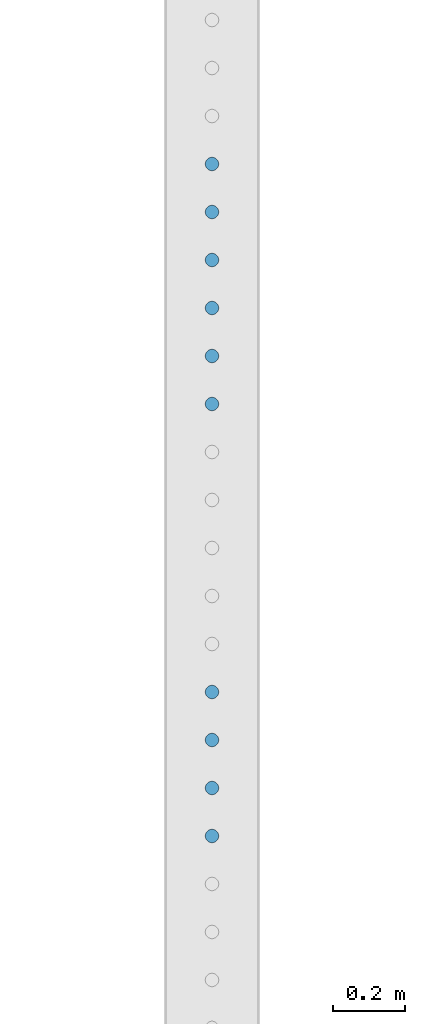
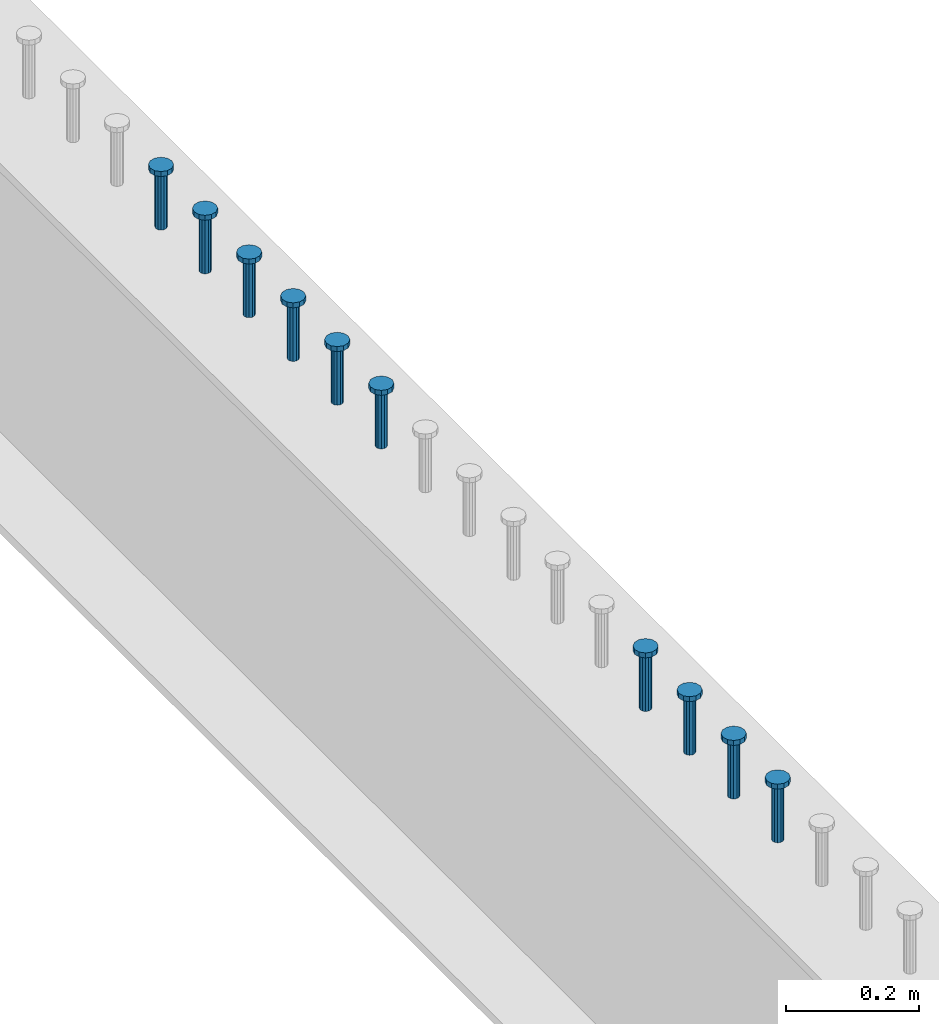
# One storey, part 944 of 1763: 10 columns, 10 elements without a shape of their own.
"""IFC2X3 building model written with IfcOpenShell, lengths in millimetres."""

from ifc_helpers import new_model, si_unit, frame, origin_with_axes, place, context, subcontext, project, spatial, faceted_brep, material, type_object, element, aggregate, save


model = new_model("IFC2X3")

# Units and contexts
model_context = context("Model", 3, precision=1e-05, world=origin_with_axes())
body_context = subcontext(model_context, "Body", "Model", "MODEL_VIEW")
ifc_project = project(units=[si_unit("LENGTHUNIT", "METRE", prefix="MILLI"), si_unit("AREAUNIT", "SQUARE_METRE"), si_unit("VOLUMEUNIT", "CUBIC_METRE"), si_unit("MASSUNIT", "GRAM", prefix="KILO"), si_unit("TIMEUNIT", "SECOND"), si_unit("PLANEANGLEUNIT", "RADIAN"), si_unit("SOLIDANGLEUNIT", "STERADIAN"), si_unit("THERMODYNAMICTEMPERATUREUNIT", "DEGREE_CELSIUS"), si_unit("LUMINOUSINTENSITYUNIT", "LUMEN")], contexts=[model_context])

# Site, building, storey
site_placement = place(None, origin_with_axes())
site = spatial("IfcSite", under=ifc_project, at=site_placement, CompositionType="ELEMENT")
building_placement = place(site_placement, origin_with_axes())
building = spatial("IfcBuilding", under=site, at=building_placement, Name="Undefined", CompositionType="ELEMENT")
storey_placement = place(building_placement, origin_with_axes())
storey = spatial("IfcBuildingStorey", under=building, at=storey_placement, Name="Undefined", CompositionType="ELEMENT", Elevation=0.0)

# Assembly, column
assembly_1_placement = place(storey_placement, origin_with_axes())
assembly_1 = element("IfcElementAssembly", 1, at=assembly_1_placement, inside=storey, Name="STUD", AssemblyPlace="NOTDEFINED", PredefinedType="RIGID_FRAME")
ifc_material = material(Name="STEEL/A108")
column_type = type_object("IfcColumnType", Name="STUD_3/4-DIA", PredefinedType="NOTDEFINED")
column_1_placement = place(assembly_1_placement, frame((-24027.8372736984, 36950.0625, 5194.3), z_axis=(-1.0, 0.0, 0.0), x_axis=(0.0, 0.0, 1.0)))
column_1 = element("IfcColumn", 2, at=column_1_placement, type_object=column_type, material=ifc_material, Name="STUD", ObjectType="STUD_3/4-DIA", context=body_context, shape_type="Brep", body=[
    faceted_brep([(0.0, -9.52000045776367, 0.0), (0.0, -8.25, -4.76000022888184), (104.013, -8.25, -4.76000022888184), (104.013, -9.52000045776367, 0.0), (0.0, -4.76000022888184, -8.25), (104.013, -4.76000022888184, -8.25), (0.0, 0.0, -9.52000045776367), (104.013, 0.0, -9.52000045776367), (0.0, 4.76000022888184, -8.25), (104.013, 4.76000022888184, -8.25), (0.0, 8.25, -4.76000022888184), (104.013, 8.25, -4.76000022888184), (0.0, 9.52000045776367, 0.0), (104.013, 9.52000045776367, 0.0), (0.0, 8.25, 4.76000022888184), (104.013, 8.25, 4.76000022888184), (0.0, 4.76000022888184, 8.25), (104.013, 4.76000022888184, 8.25), (0.0, 0.0, 9.52000045776367), (104.013, 0.0, 9.52000045776367), (0.0, -4.76000022888184, 8.25), (104.013, -4.76000022888184, 8.25), (0.0, -8.25, 4.76000022888184), (104.013, -8.25, 4.76000022888184), (105.156, -16.5, -9.52000045776367), (105.156, -19.0499992370605, 0.0), (105.156, -9.52000045776367, -16.5), (105.156, 0.0, -19.0499992370605), (105.156, 9.52000045776367, -16.5), (105.156, 16.5, -9.52000045776367), (105.156, 19.0499992370605, 0.0), (105.156, 16.5, 9.52000045776367), (105.156, 9.52000045776367, 16.5), (105.156, 0.0, 19.0499992370605), (105.156, -9.52000045776367, 16.5), (105.156, -16.5, 9.52000045776367), (114.3, -16.5, -9.52000045776367), (114.299998441489, -19.0500000000029, 0.0), (114.3, -9.52000045776367, -16.5), (114.3, 0.0, -19.0499992370605), (114.3, 9.52000045776367, -16.5), (114.3, 16.5, -9.52000045776367), (114.299998441489, 19.0500000000029, 0.0), (114.3, 16.5, 9.52000045776367), (114.3, 9.52000045776367, 16.5), (114.3, 0.0, 19.0499992370605), (114.3, -9.52000045776367, 16.5), (114.3, -16.5, 9.52000045776367)], [[[0, 1, 2, 3]], [[1, 4, 5, 2]], [[4, 6, 7, 5]], [[6, 8, 9, 7]], [[8, 10, 11, 9]], [[10, 12, 13, 11]], [[12, 14, 15, 13]], [[14, 16, 17, 15]], [[16, 18, 19, 17]], [[18, 20, 21, 19]], [[20, 22, 23, 21]], [[22, 0, 3, 23]], [[22, 20, 18, 16, 14, 12, 10, 8, 6, 4, 1, 0]], [[3, 2, 24, 25]], [[2, 5, 26, 24]], [[5, 7, 27, 26]], [[7, 9, 28, 27]], [[9, 11, 29, 28]], [[11, 13, 30, 29]], [[13, 15, 31, 30]], [[15, 17, 32, 31]], [[17, 19, 33, 32]], [[19, 21, 34, 33]], [[21, 23, 35, 34]], [[23, 3, 25, 35]], [[25, 24, 36, 37]], [[24, 26, 38, 36]], [[26, 27, 39, 38]], [[27, 28, 40, 39]], [[28, 29, 41, 40]], [[29, 30, 42, 41]], [[30, 31, 43, 42]], [[31, 32, 44, 43]], [[32, 33, 45, 44]], [[33, 34, 46, 45]], [[34, 35, 47, 46]], [[35, 25, 37, 47]], [[38, 39, 40, 41, 42, 43, 44, 45, 46, 47, 37, 36]]]),
])
aggregate(assembly_1, [column_1])

assembly_2_placement = place(storey_placement, origin_with_axes())
assembly_2 = element("IfcElementAssembly", 3, at=assembly_2_placement, inside=storey, Name="STUD", AssemblyPlace="NOTDEFINED", PredefinedType="RIGID_FRAME")
column_2_placement = place(assembly_2_placement, frame((-24027.8372736984, 36817.4545, 5194.3), z_axis=(-1.0, 0.0, 0.0), x_axis=(0.0, 0.0, 1.0)))
column_2 = element("IfcColumn", 4, at=column_2_placement, type_object=column_type, material=ifc_material, Name="STUD", ObjectType="STUD_3/4-DIA", context=body_context, shape_type="Brep", body=[
    faceted_brep([(0.0, -9.52000045776367, 0.0), (0.0, -8.25, -4.76000022888184), (104.013, -8.25, -4.76000022888184), (104.013, -9.52000045776367, 0.0), (0.0, -4.76000022888184, -8.25), (104.013, -4.76000022888184, -8.25), (0.0, 0.0, -9.52000045776367), (104.013, 0.0, -9.52000045776367), (0.0, 4.76000022888184, -8.25), (104.013, 4.76000022888184, -8.25), (0.0, 8.25, -4.76000022888184), (104.013, 8.25, -4.76000022888184), (0.0, 9.52000045776367, 0.0), (104.013, 9.52000045776367, 0.0), (0.0, 8.25, 4.76000022888184), (104.013, 8.25, 4.76000022888184), (0.0, 4.76000022888184, 8.25), (104.013, 4.76000022888184, 8.25), (0.0, 0.0, 9.52000045776367), (104.013, 0.0, 9.52000045776367), (0.0, -4.76000022888184, 8.25), (104.013, -4.76000022888184, 8.25), (0.0, -8.25, 4.76000022888184), (104.013, -8.25, 4.76000022888184), (105.156, -16.5, -9.52000045776367), (105.156, -19.0499992370605, 0.0), (105.156, -9.52000045776367, -16.5), (105.156, 0.0, -19.0499992370605), (105.156, 9.52000045776367, -16.5), (105.156, 16.5, -9.52000045776367), (105.156, 19.0499992370605, 0.0), (105.156, 16.5, 9.52000045776367), (105.156, 9.52000045776367, 16.5), (105.156, 0.0, 19.0499992370605), (105.156, -9.52000045776367, 16.5), (105.156, -16.5, 9.52000045776367), (114.3, -16.5, -9.52000045776367), (114.299998441489, -19.0500000000029, 0.0), (114.3, -9.52000045776367, -16.5), (114.3, 0.0, -19.0499992370605), (114.3, 9.52000045776367, -16.5), (114.3, 16.5, -9.52000045776367), (114.299998441489, 19.0500000000029, 0.0), (114.3, 16.5, 9.52000045776367), (114.3, 9.52000045776367, 16.5), (114.3, 0.0, 19.0499992370605), (114.3, -9.52000045776367, 16.5), (114.3, -16.5, 9.52000045776367)], [[[0, 1, 2, 3]], [[1, 4, 5, 2]], [[4, 6, 7, 5]], [[6, 8, 9, 7]], [[8, 10, 11, 9]], [[10, 12, 13, 11]], [[12, 14, 15, 13]], [[14, 16, 17, 15]], [[16, 18, 19, 17]], [[18, 20, 21, 19]], [[20, 22, 23, 21]], [[22, 0, 3, 23]], [[22, 20, 18, 16, 14, 12, 10, 8, 6, 4, 1, 0]], [[3, 2, 24, 25]], [[2, 5, 26, 24]], [[5, 7, 27, 26]], [[7, 9, 28, 27]], [[9, 11, 29, 28]], [[11, 13, 30, 29]], [[13, 15, 31, 30]], [[15, 17, 32, 31]], [[17, 19, 33, 32]], [[19, 21, 34, 33]], [[21, 23, 35, 34]], [[23, 3, 25, 35]], [[25, 24, 36, 37]], [[24, 26, 38, 36]], [[26, 27, 39, 38]], [[27, 28, 40, 39]], [[28, 29, 41, 40]], [[29, 30, 42, 41]], [[30, 31, 43, 42]], [[31, 32, 44, 43]], [[32, 33, 45, 44]], [[33, 34, 46, 45]], [[34, 35, 47, 46]], [[35, 25, 37, 47]], [[38, 39, 40, 41, 42, 43, 44, 45, 46, 47, 37, 36]]]),
])
aggregate(assembly_2, [column_2])

assembly_3_placement = place(storey_placement, origin_with_axes())
assembly_3 = element("IfcElementAssembly", 5, at=assembly_3_placement, inside=storey, Name="STUD", AssemblyPlace="NOTDEFINED", PredefinedType="RIGID_FRAME")
column_3_placement = place(assembly_3_placement, frame((-24027.8372736984, 36684.8465, 5194.3), z_axis=(-1.0, 0.0, 0.0), x_axis=(0.0, 0.0, 1.0)))
column_3 = element("IfcColumn", 6, at=column_3_placement, type_object=column_type, material=ifc_material, Name="STUD", ObjectType="STUD_3/4-DIA", context=body_context, shape_type="Brep", body=[
    faceted_brep([(0.0, -9.52000045776367, 0.0), (0.0, -8.25, -4.76000022888184), (104.013, -8.25, -4.76000022888184), (104.013, -9.52000045776367, 0.0), (0.0, -4.76000022888184, -8.25), (104.013, -4.76000022888184, -8.25), (0.0, 0.0, -9.52000045776367), (104.013, 0.0, -9.52000045776367), (0.0, 4.76000022888184, -8.25), (104.013, 4.76000022888184, -8.25), (0.0, 8.25, -4.76000022888184), (104.013, 8.25, -4.76000022888184), (0.0, 9.52000045776367, 0.0), (104.013, 9.52000045776367, 0.0), (0.0, 8.25, 4.76000022888184), (104.013, 8.25, 4.76000022888184), (0.0, 4.76000022888184, 8.25), (104.013, 4.76000022888184, 8.25), (0.0, 0.0, 9.52000045776367), (104.013, 0.0, 9.52000045776367), (0.0, -4.76000022888184, 8.25), (104.013, -4.76000022888184, 8.25), (0.0, -8.25, 4.76000022888184), (104.013, -8.25, 4.76000022888184), (105.156, -16.5, -9.52000045776367), (105.156, -19.0499992370605, 0.0), (105.156, -9.52000045776367, -16.5), (105.156, 0.0, -19.0499992370605), (105.156, 9.52000045776367, -16.5), (105.156, 16.5, -9.52000045776367), (105.156, 19.0499992370605, 0.0), (105.156, 16.5, 9.52000045776367), (105.156, 9.52000045776367, 16.5), (105.156, 0.0, 19.0499992370605), (105.156, -9.52000045776367, 16.5), (105.156, -16.5, 9.52000045776367), (114.3, -16.5, -9.52000045776367), (114.299998441489, -19.0500000000029, 0.0), (114.3, -9.52000045776367, -16.5), (114.3, 0.0, -19.0499992370605), (114.3, 9.52000045776367, -16.5), (114.3, 16.5, -9.52000045776367), (114.299998441489, 19.0500000000029, 0.0), (114.3, 16.5, 9.52000045776367), (114.3, 9.52000045776367, 16.5), (114.3, 0.0, 19.0499992370605), (114.3, -9.52000045776367, 16.5), (114.3, -16.5, 9.52000045776367)], [[[0, 1, 2, 3]], [[1, 4, 5, 2]], [[4, 6, 7, 5]], [[6, 8, 9, 7]], [[8, 10, 11, 9]], [[10, 12, 13, 11]], [[12, 14, 15, 13]], [[14, 16, 17, 15]], [[16, 18, 19, 17]], [[18, 20, 21, 19]], [[20, 22, 23, 21]], [[22, 0, 3, 23]], [[22, 20, 18, 16, 14, 12, 10, 8, 6, 4, 1, 0]], [[3, 2, 24, 25]], [[2, 5, 26, 24]], [[5, 7, 27, 26]], [[7, 9, 28, 27]], [[9, 11, 29, 28]], [[11, 13, 30, 29]], [[13, 15, 31, 30]], [[15, 17, 32, 31]], [[17, 19, 33, 32]], [[19, 21, 34, 33]], [[21, 23, 35, 34]], [[23, 3, 25, 35]], [[25, 24, 36, 37]], [[24, 26, 38, 36]], [[26, 27, 39, 38]], [[27, 28, 40, 39]], [[28, 29, 41, 40]], [[29, 30, 42, 41]], [[30, 31, 43, 42]], [[31, 32, 44, 43]], [[32, 33, 45, 44]], [[33, 34, 46, 45]], [[34, 35, 47, 46]], [[35, 25, 37, 47]], [[38, 39, 40, 41, 42, 43, 44, 45, 46, 47, 37, 36]]]),
])
aggregate(assembly_3, [column_3])

assembly_4_placement = place(storey_placement, origin_with_axes())
assembly_4 = element("IfcElementAssembly", 7, at=assembly_4_placement, inside=storey, Name="STUD", AssemblyPlace="NOTDEFINED", PredefinedType="RIGID_FRAME")
column_4_placement = place(assembly_4_placement, frame((-24027.8372736984, 36552.2385, 5194.3), z_axis=(-1.0, 0.0, 0.0), x_axis=(0.0, 0.0, 1.0)))
column_4 = element("IfcColumn", 8, at=column_4_placement, type_object=column_type, material=ifc_material, Name="STUD", ObjectType="STUD_3/4-DIA", context=body_context, shape_type="Brep", body=[
    faceted_brep([(0.0, -9.52000045776367, 0.0), (0.0, -8.25, -4.76000022888184), (104.013, -8.25, -4.76000022888184), (104.013, -9.52000045776367, 0.0), (0.0, -4.76000022888184, -8.25), (104.013, -4.76000022888184, -8.25), (0.0, 0.0, -9.52000045776367), (104.013, 0.0, -9.52000045776367), (0.0, 4.76000022888184, -8.25), (104.013, 4.76000022888184, -8.25), (0.0, 8.25, -4.76000022888184), (104.013, 8.25, -4.76000022888184), (0.0, 9.52000045776367, 0.0), (104.013, 9.52000045776367, 0.0), (0.0, 8.25, 4.76000022888184), (104.013, 8.25, 4.76000022888184), (0.0, 4.76000022888184, 8.25), (104.013, 4.76000022888184, 8.25), (0.0, 0.0, 9.52000045776367), (104.013, 0.0, 9.52000045776367), (0.0, -4.76000022888184, 8.25), (104.013, -4.76000022888184, 8.25), (0.0, -8.25, 4.76000022888184), (104.013, -8.25, 4.76000022888184), (105.156, -16.5, -9.52000045776367), (105.156, -19.0499992370605, 0.0), (105.156, -9.52000045776367, -16.5), (105.156, 0.0, -19.0499992370605), (105.156, 9.52000045776367, -16.5), (105.156, 16.5, -9.52000045776367), (105.156, 19.0499992370605, 0.0), (105.156, 16.5, 9.52000045776367), (105.156, 9.52000045776367, 16.5), (105.156, 0.0, 19.0499992370605), (105.156, -9.52000045776367, 16.5), (105.156, -16.5, 9.52000045776367), (114.3, -16.5, -9.52000045776367), (114.299998441489, -19.0500000000029, 0.0), (114.3, -9.52000045776367, -16.5), (114.3, 0.0, -19.0499992370605), (114.3, 9.52000045776367, -16.5), (114.3, 16.5, -9.52000045776367), (114.299998441489, 19.0500000000029, 0.0), (114.3, 16.5, 9.52000045776367), (114.3, 9.52000045776367, 16.5), (114.3, 0.0, 19.0499992370605), (114.3, -9.52000045776367, 16.5), (114.3, -16.5, 9.52000045776367)], [[[0, 1, 2, 3]], [[1, 4, 5, 2]], [[4, 6, 7, 5]], [[6, 8, 9, 7]], [[8, 10, 11, 9]], [[10, 12, 13, 11]], [[12, 14, 15, 13]], [[14, 16, 17, 15]], [[16, 18, 19, 17]], [[18, 20, 21, 19]], [[20, 22, 23, 21]], [[22, 0, 3, 23]], [[22, 20, 18, 16, 14, 12, 10, 8, 6, 4, 1, 0]], [[3, 2, 24, 25]], [[2, 5, 26, 24]], [[5, 7, 27, 26]], [[7, 9, 28, 27]], [[9, 11, 29, 28]], [[11, 13, 30, 29]], [[13, 15, 31, 30]], [[15, 17, 32, 31]], [[17, 19, 33, 32]], [[19, 21, 34, 33]], [[21, 23, 35, 34]], [[23, 3, 25, 35]], [[25, 24, 36, 37]], [[24, 26, 38, 36]], [[26, 27, 39, 38]], [[27, 28, 40, 39]], [[28, 29, 41, 40]], [[29, 30, 42, 41]], [[30, 31, 43, 42]], [[31, 32, 44, 43]], [[32, 33, 45, 44]], [[33, 34, 46, 45]], [[34, 35, 47, 46]], [[35, 25, 37, 47]], [[38, 39, 40, 41, 42, 43, 44, 45, 46, 47, 37, 36]]]),
])
aggregate(assembly_4, [column_4])

assembly_5_placement = place(storey_placement, origin_with_axes())
assembly_5 = element("IfcElementAssembly", 9, at=assembly_5_placement, inside=storey, Name="STUD", AssemblyPlace="NOTDEFINED", PredefinedType="RIGID_FRAME")
column_5_placement = place(assembly_5_placement, frame((-24027.8372736984, 36419.6305, 5194.3), z_axis=(-1.0, 0.0, 0.0), x_axis=(0.0, 0.0, 1.0)))
column_5 = element("IfcColumn", 10, at=column_5_placement, type_object=column_type, material=ifc_material, Name="STUD", ObjectType="STUD_3/4-DIA", context=body_context, shape_type="Brep", body=[
    faceted_brep([(0.0, -9.52000045776367, 0.0), (0.0, -8.25, -4.76000022888184), (104.013, -8.25, -4.76000022888184), (104.013, -9.52000045776367, 0.0), (0.0, -4.76000022888184, -8.25), (104.013, -4.76000022888184, -8.25), (0.0, 0.0, -9.52000045776367), (104.013, 0.0, -9.52000045776367), (0.0, 4.76000022888184, -8.25), (104.013, 4.76000022888184, -8.25), (0.0, 8.25, -4.76000022888184), (104.013, 8.25, -4.76000022888184), (0.0, 9.52000045776367, 0.0), (104.013, 9.52000045776367, 0.0), (0.0, 8.25, 4.76000022888184), (104.013, 8.25, 4.76000022888184), (0.0, 4.76000022888184, 8.25), (104.013, 4.76000022888184, 8.25), (0.0, 0.0, 9.52000045776367), (104.013, 0.0, 9.52000045776367), (0.0, -4.76000022888184, 8.25), (104.013, -4.76000022888184, 8.25), (0.0, -8.25, 4.76000022888184), (104.013, -8.25, 4.76000022888184), (105.156, -16.5, -9.52000045776367), (105.156, -19.0499992370605, 0.0), (105.156, -9.52000045776367, -16.5), (105.156, 0.0, -19.0499992370605), (105.156, 9.52000045776367, -16.5), (105.156, 16.5, -9.52000045776367), (105.156, 19.0499992370605, 0.0), (105.156, 16.5, 9.52000045776367), (105.156, 9.52000045776367, 16.5), (105.156, 0.0, 19.0499992370605), (105.156, -9.52000045776367, 16.5), (105.156, -16.5, 9.52000045776367), (114.3, -16.5, -9.52000045776367), (114.299998441489, -19.0500000000029, 0.0), (114.3, -9.52000045776367, -16.5), (114.3, 0.0, -19.0499992370605), (114.3, 9.52000045776367, -16.5), (114.3, 16.5, -9.52000045776367), (114.299998441489, 19.0500000000029, 0.0), (114.3, 16.5, 9.52000045776367), (114.3, 9.52000045776367, 16.5), (114.3, 0.0, 19.0499992370605), (114.3, -9.52000045776367, 16.5), (114.3, -16.5, 9.52000045776367)], [[[0, 1, 2, 3]], [[1, 4, 5, 2]], [[4, 6, 7, 5]], [[6, 8, 9, 7]], [[8, 10, 11, 9]], [[10, 12, 13, 11]], [[12, 14, 15, 13]], [[14, 16, 17, 15]], [[16, 18, 19, 17]], [[18, 20, 21, 19]], [[20, 22, 23, 21]], [[22, 0, 3, 23]], [[22, 20, 18, 16, 14, 12, 10, 8, 6, 4, 1, 0]], [[3, 2, 24, 25]], [[2, 5, 26, 24]], [[5, 7, 27, 26]], [[7, 9, 28, 27]], [[9, 11, 29, 28]], [[11, 13, 30, 29]], [[13, 15, 31, 30]], [[15, 17, 32, 31]], [[17, 19, 33, 32]], [[19, 21, 34, 33]], [[21, 23, 35, 34]], [[23, 3, 25, 35]], [[25, 24, 36, 37]], [[24, 26, 38, 36]], [[26, 27, 39, 38]], [[27, 28, 40, 39]], [[28, 29, 41, 40]], [[29, 30, 42, 41]], [[30, 31, 43, 42]], [[31, 32, 44, 43]], [[32, 33, 45, 44]], [[33, 34, 46, 45]], [[34, 35, 47, 46]], [[35, 25, 37, 47]], [[38, 39, 40, 41, 42, 43, 44, 45, 46, 47, 37, 36]]]),
])
aggregate(assembly_5, [column_5])

assembly_6_placement = place(storey_placement, origin_with_axes())
assembly_6 = element("IfcElementAssembly", 11, at=assembly_6_placement, inside=storey, Name="STUD", AssemblyPlace="NOTDEFINED", PredefinedType="RIGID_FRAME")
column_6_placement = place(assembly_6_placement, frame((-24027.8372736984, 36287.0225, 5194.3), z_axis=(-1.0, 0.0, 0.0), x_axis=(0.0, 0.0, 1.0)))
column_6 = element("IfcColumn", 12, at=column_6_placement, type_object=column_type, material=ifc_material, Name="STUD", ObjectType="STUD_3/4-DIA", context=body_context, shape_type="Brep", body=[
    faceted_brep([(0.0, -9.52000045776367, 0.0), (0.0, -8.25, -4.76000022888184), (104.013, -8.25, -4.76000022888184), (104.013, -9.52000045776367, 0.0), (0.0, -4.76000022888184, -8.25), (104.013, -4.76000022888184, -8.25), (0.0, 0.0, -9.52000045776367), (104.013, 0.0, -9.52000045776367), (0.0, 4.76000022888184, -8.25), (104.013, 4.76000022888184, -8.25), (0.0, 8.25, -4.76000022888184), (104.013, 8.25, -4.76000022888184), (0.0, 9.52000045776367, 0.0), (104.013, 9.52000045776367, 0.0), (0.0, 8.25, 4.76000022888184), (104.013, 8.25, 4.76000022888184), (0.0, 4.76000022888184, 8.25), (104.013, 4.76000022888184, 8.25), (0.0, 0.0, 9.52000045776367), (104.013, 0.0, 9.52000045776367), (0.0, -4.76000022888184, 8.25), (104.013, -4.76000022888184, 8.25), (0.0, -8.25, 4.76000022888184), (104.013, -8.25, 4.76000022888184), (105.156, -16.5, -9.52000045776367), (105.156, -19.0499992370605, 0.0), (105.156, -9.52000045776367, -16.5), (105.156, 0.0, -19.0499992370605), (105.156, 9.52000045776367, -16.5), (105.156, 16.5, -9.52000045776367), (105.156, 19.0499992370605, 0.0), (105.156, 16.5, 9.52000045776367), (105.156, 9.52000045776367, 16.5), (105.156, 0.0, 19.0499992370605), (105.156, -9.52000045776367, 16.5), (105.156, -16.5, 9.52000045776367), (114.3, -16.5, -9.52000045776367), (114.299998441489, -19.0500000000029, 0.0), (114.3, -9.52000045776367, -16.5), (114.3, 0.0, -19.0499992370605), (114.3, 9.52000045776367, -16.5), (114.3, 16.5, -9.52000045776367), (114.299998441489, 19.0500000000029, 0.0), (114.3, 16.5, 9.52000045776367), (114.3, 9.52000045776367, 16.5), (114.3, 0.0, 19.0499992370605), (114.3, -9.52000045776367, 16.5), (114.3, -16.5, 9.52000045776367)], [[[0, 1, 2, 3]], [[1, 4, 5, 2]], [[4, 6, 7, 5]], [[6, 8, 9, 7]], [[8, 10, 11, 9]], [[10, 12, 13, 11]], [[12, 14, 15, 13]], [[14, 16, 17, 15]], [[16, 18, 19, 17]], [[18, 20, 21, 19]], [[20, 22, 23, 21]], [[22, 0, 3, 23]], [[22, 20, 18, 16, 14, 12, 10, 8, 6, 4, 1, 0]], [[3, 2, 24, 25]], [[2, 5, 26, 24]], [[5, 7, 27, 26]], [[7, 9, 28, 27]], [[9, 11, 29, 28]], [[11, 13, 30, 29]], [[13, 15, 31, 30]], [[15, 17, 32, 31]], [[17, 19, 33, 32]], [[19, 21, 34, 33]], [[21, 23, 35, 34]], [[23, 3, 25, 35]], [[25, 24, 36, 37]], [[24, 26, 38, 36]], [[26, 27, 39, 38]], [[27, 28, 40, 39]], [[28, 29, 41, 40]], [[29, 30, 42, 41]], [[30, 31, 43, 42]], [[31, 32, 44, 43]], [[32, 33, 45, 44]], [[33, 34, 46, 45]], [[34, 35, 47, 46]], [[35, 25, 37, 47]], [[38, 39, 40, 41, 42, 43, 44, 45, 46, 47, 37, 36]]]),
])
aggregate(assembly_6, [column_6])

assembly_7_placement = place(storey_placement, origin_with_axes())
assembly_7 = element("IfcElementAssembly", 13, at=assembly_7_placement, inside=storey, Name="STUD", AssemblyPlace="NOTDEFINED", PredefinedType="RIGID_FRAME")
column_7_placement = place(assembly_7_placement, frame((-24027.8372736984, 35491.3745, 5194.3), z_axis=(-1.0, 0.0, 0.0), x_axis=(0.0, 0.0, 1.0)))
column_7 = element("IfcColumn", 14, at=column_7_placement, type_object=column_type, material=ifc_material, Name="STUD", ObjectType="STUD_3/4-DIA", context=body_context, shape_type="Brep", body=[
    faceted_brep([(0.0, -9.52000045776367, 0.0), (0.0, -8.25, -4.76000022888184), (104.013, -8.25, -4.76000022888184), (104.013, -9.52000045776367, 0.0), (0.0, -4.76000022888184, -8.25), (104.013, -4.76000022888184, -8.25), (0.0, 0.0, -9.52000045776367), (104.013, 0.0, -9.52000045776367), (0.0, 4.76000022888184, -8.25), (104.013, 4.76000022888184, -8.25), (0.0, 8.25, -4.76000022888184), (104.013, 8.25, -4.76000022888184), (0.0, 9.52000045776367, 0.0), (104.013, 9.52000045776367, 0.0), (0.0, 8.25, 4.76000022888184), (104.013, 8.25, 4.76000022888184), (0.0, 4.76000022888184, 8.25), (104.013, 4.76000022888184, 8.25), (0.0, 0.0, 9.52000045776367), (104.013, 0.0, 9.52000045776367), (0.0, -4.76000022888184, 8.25), (104.013, -4.76000022888184, 8.25), (0.0, -8.25, 4.76000022888184), (104.013, -8.25, 4.76000022888184), (105.156, -16.5, -9.52000045776367), (105.156, -19.0499992370605, 0.0), (105.156, -9.52000045776367, -16.5), (105.156, 0.0, -19.0499992370605), (105.156, 9.52000045776367, -16.5), (105.156, 16.5, -9.52000045776367), (105.156, 19.0499992370605, 0.0), (105.156, 16.5, 9.52000045776367), (105.156, 9.52000045776367, 16.5), (105.156, 0.0, 19.0499992370605), (105.156, -9.52000045776367, 16.5), (105.156, -16.5, 9.52000045776367), (114.3, -16.5, -9.52000045776367), (114.299998441489, -19.0500000000029, 0.0), (114.3, -9.52000045776367, -16.5), (114.3, 0.0, -19.0499992370605), (114.3, 9.52000045776367, -16.5), (114.3, 16.5, -9.52000045776367), (114.299998441489, 19.0500000000029, 0.0), (114.3, 16.5, 9.52000045776367), (114.3, 9.52000045776367, 16.5), (114.3, 0.0, 19.0499992370605), (114.3, -9.52000045776367, 16.5), (114.3, -16.5, 9.52000045776367)], [[[0, 1, 2, 3]], [[1, 4, 5, 2]], [[4, 6, 7, 5]], [[6, 8, 9, 7]], [[8, 10, 11, 9]], [[10, 12, 13, 11]], [[12, 14, 15, 13]], [[14, 16, 17, 15]], [[16, 18, 19, 17]], [[18, 20, 21, 19]], [[20, 22, 23, 21]], [[22, 0, 3, 23]], [[22, 20, 18, 16, 14, 12, 10, 8, 6, 4, 1, 0]], [[3, 2, 24, 25]], [[2, 5, 26, 24]], [[5, 7, 27, 26]], [[7, 9, 28, 27]], [[9, 11, 29, 28]], [[11, 13, 30, 29]], [[13, 15, 31, 30]], [[15, 17, 32, 31]], [[17, 19, 33, 32]], [[19, 21, 34, 33]], [[21, 23, 35, 34]], [[23, 3, 25, 35]], [[25, 24, 36, 37]], [[24, 26, 38, 36]], [[26, 27, 39, 38]], [[27, 28, 40, 39]], [[28, 29, 41, 40]], [[29, 30, 42, 41]], [[30, 31, 43, 42]], [[31, 32, 44, 43]], [[32, 33, 45, 44]], [[33, 34, 46, 45]], [[34, 35, 47, 46]], [[35, 25, 37, 47]], [[38, 39, 40, 41, 42, 43, 44, 45, 46, 47, 37, 36]]]),
])
aggregate(assembly_7, [column_7])

assembly_8_placement = place(storey_placement, origin_with_axes())
assembly_8 = element("IfcElementAssembly", 15, at=assembly_8_placement, inside=storey, Name="STUD", AssemblyPlace="NOTDEFINED", PredefinedType="RIGID_FRAME")
column_8_placement = place(assembly_8_placement, frame((-24027.8372736984, 35358.7665, 5194.3), z_axis=(-1.0, 0.0, 0.0), x_axis=(0.0, 0.0, 1.0)))
column_8 = element("IfcColumn", 16, at=column_8_placement, type_object=column_type, material=ifc_material, Name="STUD", ObjectType="STUD_3/4-DIA", context=body_context, shape_type="Brep", body=[
    faceted_brep([(0.0, -9.52000045776367, 0.0), (0.0, -8.25, -4.76000022888184), (104.013, -8.25, -4.76000022888184), (104.013, -9.52000045776367, 0.0), (0.0, -4.76000022888184, -8.25), (104.013, -4.76000022888184, -8.25), (0.0, 0.0, -9.52000045776367), (104.013, 0.0, -9.52000045776367), (0.0, 4.76000022888184, -8.25), (104.013, 4.76000022888184, -8.25), (0.0, 8.25, -4.76000022888184), (104.013, 8.25, -4.76000022888184), (0.0, 9.52000045776367, 0.0), (104.013, 9.52000045776367, 0.0), (0.0, 8.25, 4.76000022888184), (104.013, 8.25, 4.76000022888184), (0.0, 4.76000022888184, 8.25), (104.013, 4.76000022888184, 8.25), (0.0, 0.0, 9.52000045776367), (104.013, 0.0, 9.52000045776367), (0.0, -4.76000022888184, 8.25), (104.013, -4.76000022888184, 8.25), (0.0, -8.25, 4.76000022888184), (104.013, -8.25, 4.76000022888184), (105.156, -16.5, -9.52000045776367), (105.156, -19.0499992370605, 0.0), (105.156, -9.52000045776367, -16.5), (105.156, 0.0, -19.0499992370605), (105.156, 9.52000045776367, -16.5), (105.156, 16.5, -9.52000045776367), (105.156, 19.0499992370605, 0.0), (105.156, 16.5, 9.52000045776367), (105.156, 9.52000045776367, 16.5), (105.156, 0.0, 19.0499992370605), (105.156, -9.52000045776367, 16.5), (105.156, -16.5, 9.52000045776367), (114.3, -16.5, -9.52000045776367), (114.299998441489, -19.0500000000029, 0.0), (114.3, -9.52000045776367, -16.5), (114.3, 0.0, -19.0499992370605), (114.3, 9.52000045776367, -16.5), (114.3, 16.5, -9.52000045776367), (114.299998441489, 19.0500000000029, 0.0), (114.3, 16.5, 9.52000045776367), (114.3, 9.52000045776367, 16.5), (114.3, 0.0, 19.0499992370605), (114.3, -9.52000045776367, 16.5), (114.3, -16.5, 9.52000045776367)], [[[0, 1, 2, 3]], [[1, 4, 5, 2]], [[4, 6, 7, 5]], [[6, 8, 9, 7]], [[8, 10, 11, 9]], [[10, 12, 13, 11]], [[12, 14, 15, 13]], [[14, 16, 17, 15]], [[16, 18, 19, 17]], [[18, 20, 21, 19]], [[20, 22, 23, 21]], [[22, 0, 3, 23]], [[22, 20, 18, 16, 14, 12, 10, 8, 6, 4, 1, 0]], [[3, 2, 24, 25]], [[2, 5, 26, 24]], [[5, 7, 27, 26]], [[7, 9, 28, 27]], [[9, 11, 29, 28]], [[11, 13, 30, 29]], [[13, 15, 31, 30]], [[15, 17, 32, 31]], [[17, 19, 33, 32]], [[19, 21, 34, 33]], [[21, 23, 35, 34]], [[23, 3, 25, 35]], [[25, 24, 36, 37]], [[24, 26, 38, 36]], [[26, 27, 39, 38]], [[27, 28, 40, 39]], [[28, 29, 41, 40]], [[29, 30, 42, 41]], [[30, 31, 43, 42]], [[31, 32, 44, 43]], [[32, 33, 45, 44]], [[33, 34, 46, 45]], [[34, 35, 47, 46]], [[35, 25, 37, 47]], [[38, 39, 40, 41, 42, 43, 44, 45, 46, 47, 37, 36]]]),
])
aggregate(assembly_8, [column_8])

assembly_9_placement = place(storey_placement, origin_with_axes())
assembly_9 = element("IfcElementAssembly", 17, at=assembly_9_placement, inside=storey, Name="STUD", AssemblyPlace="NOTDEFINED", PredefinedType="RIGID_FRAME")
column_9_placement = place(assembly_9_placement, frame((-24027.8372736984, 35226.1585, 5194.3), z_axis=(-1.0, 0.0, 0.0), x_axis=(0.0, 0.0, 1.0)))
column_9 = element("IfcColumn", 18, at=column_9_placement, type_object=column_type, material=ifc_material, Name="STUD", ObjectType="STUD_3/4-DIA", context=body_context, shape_type="Brep", body=[
    faceted_brep([(0.0, -9.52000045776367, 0.0), (0.0, -8.25, -4.76000022888184), (104.013, -8.25, -4.76000022888184), (104.013, -9.52000045776367, 0.0), (0.0, -4.76000022888184, -8.25), (104.013, -4.76000022888184, -8.25), (0.0, 0.0, -9.52000045776367), (104.013, 0.0, -9.52000045776367), (0.0, 4.76000022888184, -8.25), (104.013, 4.76000022888184, -8.25), (0.0, 8.25, -4.76000022888184), (104.013, 8.25, -4.76000022888184), (0.0, 9.52000045776367, 0.0), (104.013, 9.52000045776367, 0.0), (0.0, 8.25, 4.76000022888184), (104.013, 8.25, 4.76000022888184), (0.0, 4.76000022888184, 8.25), (104.013, 4.76000022888184, 8.25), (0.0, 0.0, 9.52000045776367), (104.013, 0.0, 9.52000045776367), (0.0, -4.76000022888184, 8.25), (104.013, -4.76000022888184, 8.25), (0.0, -8.25, 4.76000022888184), (104.013, -8.25, 4.76000022888184), (105.156, -16.5, -9.52000045776367), (105.156, -19.0499992370605, 0.0), (105.156, -9.52000045776367, -16.5), (105.156, 0.0, -19.0499992370605), (105.156, 9.52000045776367, -16.5), (105.156, 16.5, -9.52000045776367), (105.156, 19.0499992370605, 0.0), (105.156, 16.5, 9.52000045776367), (105.156, 9.52000045776367, 16.5), (105.156, 0.0, 19.0499992370605), (105.156, -9.52000045776367, 16.5), (105.156, -16.5, 9.52000045776367), (114.3, -16.5, -9.52000045776367), (114.299998441489, -19.0500000000029, 0.0), (114.3, -9.52000045776367, -16.5), (114.3, 0.0, -19.0499992370605), (114.3, 9.52000045776367, -16.5), (114.3, 16.5, -9.52000045776367), (114.299998441489, 19.0500000000029, 0.0), (114.3, 16.5, 9.52000045776367), (114.3, 9.52000045776367, 16.5), (114.3, 0.0, 19.0499992370605), (114.3, -9.52000045776367, 16.5), (114.3, -16.5, 9.52000045776367)], [[[0, 1, 2, 3]], [[1, 4, 5, 2]], [[4, 6, 7, 5]], [[6, 8, 9, 7]], [[8, 10, 11, 9]], [[10, 12, 13, 11]], [[12, 14, 15, 13]], [[14, 16, 17, 15]], [[16, 18, 19, 17]], [[18, 20, 21, 19]], [[20, 22, 23, 21]], [[22, 0, 3, 23]], [[22, 20, 18, 16, 14, 12, 10, 8, 6, 4, 1, 0]], [[3, 2, 24, 25]], [[2, 5, 26, 24]], [[5, 7, 27, 26]], [[7, 9, 28, 27]], [[9, 11, 29, 28]], [[11, 13, 30, 29]], [[13, 15, 31, 30]], [[15, 17, 32, 31]], [[17, 19, 33, 32]], [[19, 21, 34, 33]], [[21, 23, 35, 34]], [[23, 3, 25, 35]], [[25, 24, 36, 37]], [[24, 26, 38, 36]], [[26, 27, 39, 38]], [[27, 28, 40, 39]], [[28, 29, 41, 40]], [[29, 30, 42, 41]], [[30, 31, 43, 42]], [[31, 32, 44, 43]], [[32, 33, 45, 44]], [[33, 34, 46, 45]], [[34, 35, 47, 46]], [[35, 25, 37, 47]], [[38, 39, 40, 41, 42, 43, 44, 45, 46, 47, 37, 36]]]),
])
aggregate(assembly_9, [column_9])

assembly_10_placement = place(storey_placement, origin_with_axes())
assembly_10 = element("IfcElementAssembly", 19, at=assembly_10_placement, inside=storey, Name="STUD", AssemblyPlace="NOTDEFINED", PredefinedType="RIGID_FRAME")
column_10_placement = place(assembly_10_placement, frame((-24027.8372736984, 35093.5505, 5194.3), z_axis=(-1.0, 0.0, 0.0), x_axis=(0.0, 0.0, 1.0)))
column_10 = element("IfcColumn", 20, at=column_10_placement, type_object=column_type, material=ifc_material, Name="STUD", ObjectType="STUD_3/4-DIA", context=body_context, shape_type="Brep", body=[
    faceted_brep([(0.0, -9.52000045776367, 0.0), (0.0, -8.25, -4.76000022888184), (104.013, -8.25, -4.76000022888184), (104.013, -9.52000045776367, 0.0), (0.0, -4.76000022888184, -8.25), (104.013, -4.76000022888184, -8.25), (0.0, 0.0, -9.52000045776367), (104.013, 0.0, -9.52000045776367), (0.0, 4.76000022888184, -8.25), (104.013, 4.76000022888184, -8.25), (0.0, 8.25, -4.76000022888184), (104.013, 8.25, -4.76000022888184), (0.0, 9.52000045776367, 0.0), (104.013, 9.52000045776367, 0.0), (0.0, 8.25, 4.76000022888184), (104.013, 8.25, 4.76000022888184), (0.0, 4.76000022888184, 8.25), (104.013, 4.76000022888184, 8.25), (0.0, 0.0, 9.52000045776367), (104.013, 0.0, 9.52000045776367), (0.0, -4.76000022888184, 8.25), (104.013, -4.76000022888184, 8.25), (0.0, -8.25, 4.76000022888184), (104.013, -8.25, 4.76000022888184), (105.156, -16.5, -9.52000045776367), (105.156, -19.0499992370605, 0.0), (105.156, -9.52000045776367, -16.5), (105.156, 0.0, -19.0499992370605), (105.156, 9.52000045776367, -16.5), (105.156, 16.5, -9.52000045776367), (105.156, 19.0499992370605, 0.0), (105.156, 16.5, 9.52000045776367), (105.156, 9.52000045776367, 16.5), (105.156, 0.0, 19.0499992370605), (105.156, -9.52000045776367, 16.5), (105.156, -16.5, 9.52000045776367), (114.3, -16.5, -9.52000045776367), (114.299998441489, -19.0500000000029, 0.0), (114.3, -9.52000045776367, -16.5), (114.3, 0.0, -19.0499992370605), (114.3, 9.52000045776367, -16.5), (114.3, 16.5, -9.52000045776367), (114.299998441489, 19.0500000000029, 0.0), (114.3, 16.5, 9.52000045776367), (114.3, 9.52000045776367, 16.5), (114.3, 0.0, 19.0499992370605), (114.3, -9.52000045776367, 16.5), (114.3, -16.5, 9.52000045776367)], [[[0, 1, 2, 3]], [[1, 4, 5, 2]], [[4, 6, 7, 5]], [[6, 8, 9, 7]], [[8, 10, 11, 9]], [[10, 12, 13, 11]], [[12, 14, 15, 13]], [[14, 16, 17, 15]], [[16, 18, 19, 17]], [[18, 20, 21, 19]], [[20, 22, 23, 21]], [[22, 0, 3, 23]], [[22, 20, 18, 16, 14, 12, 10, 8, 6, 4, 1, 0]], [[3, 2, 24, 25]], [[2, 5, 26, 24]], [[5, 7, 27, 26]], [[7, 9, 28, 27]], [[9, 11, 29, 28]], [[11, 13, 30, 29]], [[13, 15, 31, 30]], [[15, 17, 32, 31]], [[17, 19, 33, 32]], [[19, 21, 34, 33]], [[21, 23, 35, 34]], [[23, 3, 25, 35]], [[25, 24, 36, 37]], [[24, 26, 38, 36]], [[26, 27, 39, 38]], [[27, 28, 40, 39]], [[28, 29, 41, 40]], [[29, 30, 42, 41]], [[30, 31, 43, 42]], [[31, 32, 44, 43]], [[32, 33, 45, 44]], [[33, 34, 46, 45]], [[34, 35, 47, 46]], [[35, 25, 37, 47]], [[38, 39, 40, 41, 42, 43, 44, 45, 46, 47, 37, 36]]]),
])
aggregate(assembly_10, [column_10])

save(model, "model.ifc")
